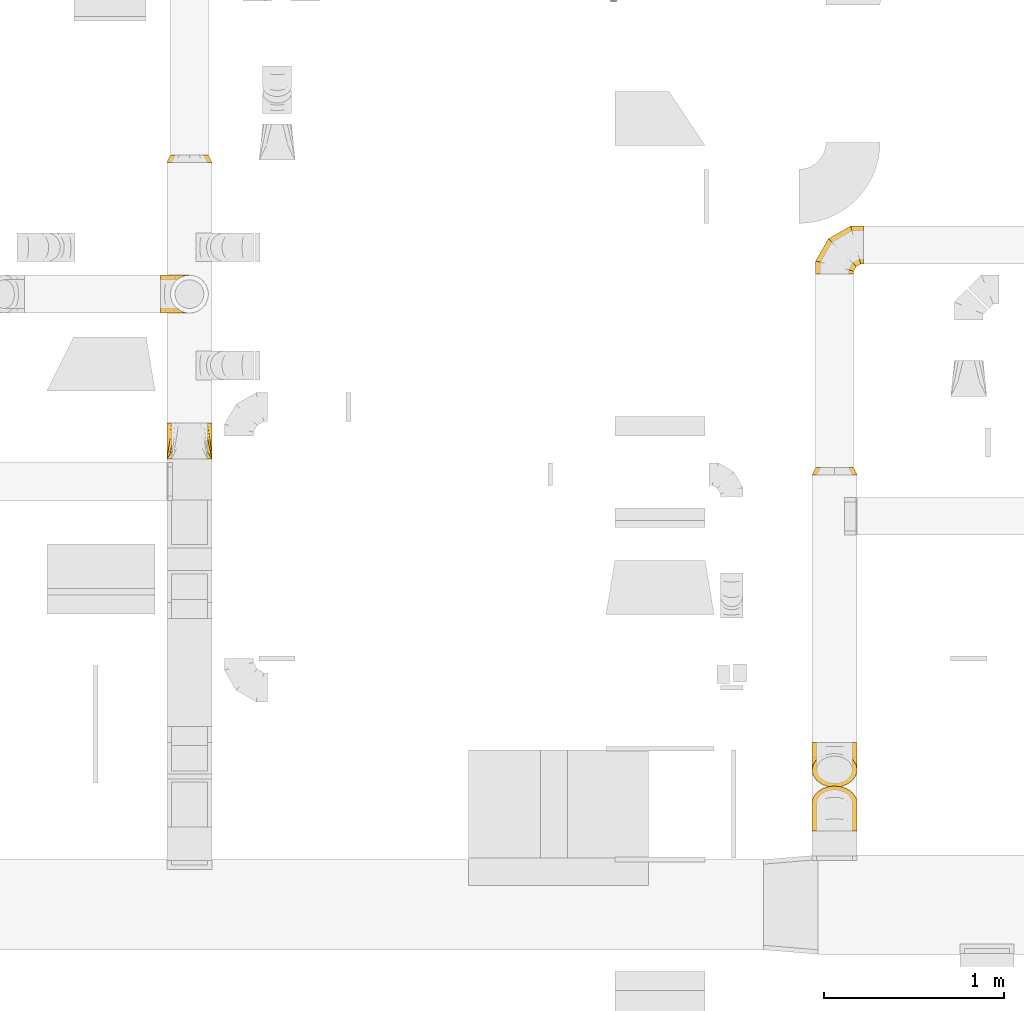
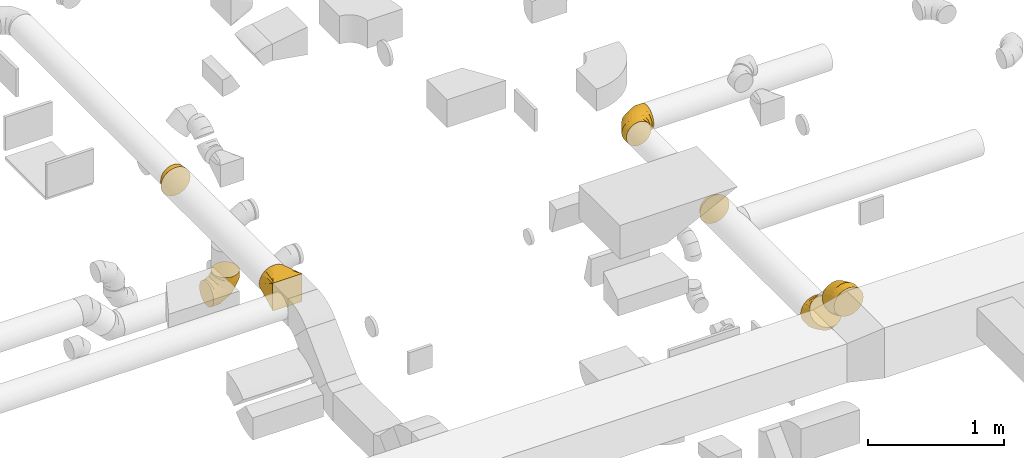
# One storey, part 9 of 62: 7 coverings.
"""IFC2X3 building model written with IfcOpenShell, lengths in millimetres."""

from ifc_helpers import new_model, entity, si_unit, converted_unit, derived_unit, direction, frame, origin, place, context, subcontext, project, spatial, faceted_brep, element, save


model = new_model("IFC2X3")

# Units and contexts
model_context = context("Model", 3, precision=0.01, world=origin(), true_north=direction((6.12303176911189e-17, 1.0)))
body_context = subcontext(model_context, "Body", "Model", "MODEL_VIEW")
ifc_project = project(units=[si_unit("LENGTHUNIT", "METRE", prefix="MILLI"), si_unit("AREAUNIT", "SQUARE_METRE"), si_unit("VOLUMEUNIT", "CUBIC_METRE"), converted_unit("PLANEANGLEUNIT", "DEGREE", entity("IfcRatioMeasure", 0.0174532925199433), si_unit("PLANEANGLEUNIT", "RADIAN"), dimensions=[0, 0, 0, 0, 0, 0, 0]), si_unit("MASSUNIT", "GRAM", prefix="KILO"), derived_unit("MASSDENSITYUNIT", [(si_unit("MASSUNIT", "GRAM", prefix="KILO"), 1), (si_unit("LENGTHUNIT", "METRE"), -3)]), derived_unit("MOMENTOFINERTIAUNIT", [(si_unit("LENGTHUNIT", "METRE"), 4)]), si_unit("TIMEUNIT", "SECOND"), si_unit("FREQUENCYUNIT", "HERTZ"), si_unit("THERMODYNAMICTEMPERATUREUNIT", "DEGREE_CELSIUS"), derived_unit("THERMALTRANSMITTANCEUNIT", [(si_unit("MASSUNIT", "GRAM", prefix="KILO"), 1), (si_unit("THERMODYNAMICTEMPERATUREUNIT", "KELVIN"), -1), (si_unit("TIMEUNIT", "SECOND"), -3)]), derived_unit("VOLUMETRICFLOWRATEUNIT", [(si_unit("LENGTHUNIT", "METRE"), 3), (si_unit("TIMEUNIT", "SECOND"), -1)]), derived_unit("MASSFLOWRATEUNIT", [(si_unit("MASSUNIT", "GRAM", prefix="KILO"), 1), (si_unit("TIMEUNIT", "SECOND"), -1)]), derived_unit("ROTATIONALFREQUENCYUNIT", [(si_unit("TIMEUNIT", "SECOND"), -1)]), si_unit("ELECTRICCURRENTUNIT", "AMPERE"), si_unit("ELECTRICVOLTAGEUNIT", "VOLT"), si_unit("POWERUNIT", "WATT"), si_unit("FORCEUNIT", "NEWTON", prefix="KILO"), si_unit("ILLUMINANCEUNIT", "LUX"), si_unit("LUMINOUSFLUXUNIT", "LUMEN"), si_unit("LUMINOUSINTENSITYUNIT", "CANDELA"), derived_unit("USERDEFINED", [(si_unit("MASSUNIT", "GRAM", prefix="KILO"), -1), (si_unit("LENGTHUNIT", "METRE"), -2), (si_unit("TIMEUNIT", "SECOND"), 3), (si_unit("LUMINOUSFLUXUNIT", "LUMEN"), 1)]), derived_unit("LINEARVELOCITYUNIT", [(si_unit("LENGTHUNIT", "METRE"), 1), (si_unit("TIMEUNIT", "SECOND"), -1)]), si_unit("PRESSUREUNIT", "PASCAL"), derived_unit("USERDEFINED", [(si_unit("LENGTHUNIT", "METRE"), -2), (si_unit("MASSUNIT", "GRAM", prefix="KILO"), 1), (si_unit("TIMEUNIT", "SECOND"), -2)]), derived_unit("LINEARFORCEUNIT", [(si_unit("MASSUNIT", "GRAM", prefix="KILO"), 1), (si_unit("LENGTHUNIT", "METRE"), 1), (si_unit("TIMEUNIT", "SECOND"), -2), (si_unit("LENGTHUNIT", "METRE"), -1)]), derived_unit("PLANARFORCEUNIT", [(si_unit("MASSUNIT", "GRAM", prefix="KILO"), 1), (si_unit("LENGTHUNIT", "METRE"), 1), (si_unit("TIMEUNIT", "SECOND"), -2), (si_unit("LENGTHUNIT", "METRE"), -2)])], contexts=[model_context])

# Site, building, storey
site_placement = place(None, origin())
site = spatial("IfcSite", under=ifc_project, at=site_placement, CompositionType="ELEMENT")
building_placement = place(site_placement, origin())
building = spatial("IfcBuilding", under=site, at=building_placement, CompositionType="ELEMENT")
storey_placement = place(building_placement, frame((0.0, 0.0, 24000.0)))
storey = spatial("IfcBuildingStorey", under=building, at=storey_placement, CompositionType="ELEMENT", Elevation=24000.0)

# Coverings
covering_1_placement = place(storey_placement, frame((50630.03, 13040.58, 3523.4)))
element("IfcCovering", 1, at=covering_1_placement, inside=storey, PredefinedType="INSULATION", context=body_context, shape_type="Brep", body=[
    faceted_brep([(159.04, 40.0, 246.46), (188.31, 40.0, 231.54), (211.54, 40.0, 208.31), (226.46, 40.0, 179.04), (231.6, 40.0, 146.6), (226.46, 40.0, 114.15), (211.54, 40.0, 84.88), (188.31, 40.0, 61.65), (159.04, 40.0, 46.73), (126.6, 40.0, 41.6), (94.15, 40.0, 46.73), (64.88, 40.0, 61.65), (41.65, 40.0, 84.88), (26.73, 40.0, 114.15), (21.6, 40.0, 146.6), (26.73, 40.0, 179.04), (41.65, 40.0, 208.31), (64.88, 40.0, 231.54), (94.15, 40.0, 246.46), (126.6, 40.0, 251.6), (126.6, 0.0, 251.6), (87.97, 0.0, 245.48), (53.12, 0.0, 227.72), (25.47, 0.0, 200.07), (7.71, 0.0, 165.22), (1.6, 0.0, 126.6), (7.71, 0.0, 87.97), (25.47, 0.0, 53.12), (53.12, 0.0, 25.47), (87.97, 0.0, 7.71), (126.6, 0.0, 1.6), (165.22, 0.0, 7.71), (200.07, 0.0, 25.47), (227.72, 0.0, 53.12), (245.48, 0.0, 87.97), (251.6, 0.0, 126.6), (245.48, 0.0, 165.22), (227.72, 0.0, 200.07), (200.07, 0.0, 227.72), (165.22, 0.0, 245.48), (237.34, 20.0, 105.59), (241.74, 19.72, 136.46), (242.49, 18.21, 135.7), (229.06, 20.0, 84.39), (207.91, 20.0, 55.28), (178.8, 20.0, 34.13), (157.6, 20.0, 25.85), (126.6, 18.21, 19.81), (95.59, 20.0, 25.85), (74.39, 20.0, 34.13), (45.28, 20.0, 55.28), (24.13, 20.0, 84.39), (15.85, 20.0, 105.59), (10.7, 18.21, 135.7), (11.46, 19.72, 136.46), (24.13, 20.0, 188.8), (45.28, 20.0, 217.91), (15.85, 20.0, 167.6), (95.59, 20.0, 247.34), (74.39, 20.0, 239.06), (126.6, 19.72, 251.6), (178.8, 20.0, 239.06), (207.91, 20.0, 217.91), (157.6, 20.0, 247.34), (237.34, 20.0, 167.6), (229.06, 20.0, 188.8)], [[[0, 1, 2, 3, 4, 5, 6, 7, 8, 9, 10, 11, 12, 13, 14, 15, 16, 17, 18, 19]], [[20, 21, 22, 23, 24, 25, 26, 27, 28, 29, 30, 31, 32, 33, 34, 35, 36, 37, 38, 39]], [[40, 4, 41, 42, 35]], [[35, 34, 40]], [[34, 33, 43]], [[40, 34, 43]], [[43, 33, 44]], [[43, 44, 6]], [[5, 43, 6]], [[43, 5, 40]], [[44, 7, 6]], [[7, 45, 8]], [[45, 32, 31]], [[45, 31, 46]], [[30, 46, 31]], [[9, 8, 46]], [[7, 44, 45]], [[4, 40, 5]], [[30, 47, 9, 46]], [[32, 44, 33]], [[44, 32, 45]], [[46, 8, 45]], [[47, 30, 48, 9]], [[30, 29, 48]], [[29, 28, 49]], [[48, 29, 49]], [[49, 28, 50]], [[49, 50, 11]], [[10, 49, 11]], [[49, 10, 48]], [[50, 12, 11]], [[12, 51, 13]], [[51, 27, 26]], [[51, 26, 52]], [[25, 52, 26]], [[14, 13, 52]], [[12, 50, 51]], [[9, 48, 10]], [[25, 53, 54, 14, 52]], [[27, 50, 28]], [[50, 27, 51]], [[52, 13, 51]], [[55, 23, 56]], [[55, 15, 57]], [[24, 23, 55]], [[57, 24, 55]], [[54, 53, 25, 57, 14]], [[55, 56, 16]], [[15, 55, 16]], [[25, 24, 57]], [[56, 17, 16]], [[58, 18, 59]], [[59, 22, 21]], [[22, 56, 23]], [[17, 59, 18]], [[19, 18, 58]], [[17, 56, 59]], [[14, 57, 15]], [[59, 21, 58]], [[20, 58, 21]], [[56, 22, 59]], [[19, 58, 20, 60]], [[61, 38, 62]], [[61, 0, 63]], [[39, 38, 61]], [[63, 39, 61]], [[60, 20, 63, 19]], [[61, 62, 1]], [[0, 61, 1]], [[20, 39, 63]], [[62, 2, 1]], [[64, 3, 65]], [[65, 37, 36]], [[37, 62, 38]], [[2, 65, 3]], [[4, 3, 64]], [[2, 62, 65]], [[19, 63, 0]], [[65, 36, 64]], [[35, 64, 36]], [[62, 37, 65]], [[4, 64, 35, 42, 41]]]),
])
covering_2_placement = place(storey_placement, frame((50630.03, 11395.58, 3523.4)))
element("IfcCovering", 2, at=covering_2_placement, inside=storey, PredefinedType="INSULATION", context=body_context, shape_type="Brep", body=[
    faceted_brep([(126.6, 200.0, 251.6), (132.56, 200.0, 250.65), (138.52, 200.0, 249.71), (150.44, 200.0, 247.82), (165.22, 200.0, 245.48), (182.65, 200.0, 236.6), (200.07, 200.0, 227.72), (213.9, 200.0, 213.9), (227.72, 200.0, 200.07), (236.6, 200.0, 182.65), (245.48, 200.0, 165.22), (247.82, 200.0, 150.44), (249.71, 200.0, 138.52), (250.65, 200.0, 132.56), (251.6, 200.0, 126.6), (250.65, 200.0, 120.63), (249.71, 200.0, 114.67), (247.82, 200.0, 102.75), (245.48, 200.0, 87.97), (236.6, 200.0, 70.55), (227.72, 200.0, 53.12), (213.9, 200.0, 39.3), (200.07, 200.0, 25.47), (182.65, 200.0, 16.59), (165.22, 200.0, 7.71), (150.44, 200.0, 5.37), (138.52, 200.0, 3.48), (132.56, 200.0, 2.54), (126.6, 200.0, 1.6), (120.63, 200.0, 2.54), (114.67, 200.0, 3.48), (102.75, 200.0, 5.37), (87.97, 200.0, 7.71), (70.55, 200.0, 16.59), (53.12, 200.0, 25.47), (39.3, 200.0, 39.3), (25.47, 200.0, 53.12), (16.59, 200.0, 70.55), (7.71, 200.0, 87.97), (5.37, 200.0, 102.75), (3.48, 200.0, 114.67), (2.54, 200.0, 120.63), (1.6, 200.0, 126.6), (2.54, 200.0, 132.56), (3.48, 200.0, 138.52), (5.37, 200.0, 150.44), (7.71, 200.0, 165.22), (16.59, 200.0, 182.65), (25.47, 200.0, 200.07), (39.3, 200.0, 213.9), (53.12, 200.0, 227.72), (70.55, 200.0, 236.6), (87.97, 200.0, 245.48), (102.75, 200.0, 247.82), (114.67, 200.0, 249.71), (120.63, 200.0, 250.65), (1.6, 0.0, 251.6), (1.6, 0.0, 1.6), (251.6, 0.0, 1.6), (251.6, 0.0, 251.6), (66.67, 104.11, 1.6), (22.66, 100.0, 17.31), (17.86, 26.03, 1.6), (50.4, 78.09, 1.6), (34.13, 52.06, 1.6), (119.1, 188.01, 1.6), (111.61, 176.03, 1.6), (96.63, 152.06, 1.6), (81.65, 128.09, 1.6), (1.6, 52.06, 34.13), (1.6, 78.09, 50.4), (1.6, 104.11, 66.67), (1.6, 128.09, 81.65), (1.6, 152.06, 96.63), (1.6, 176.03, 111.61), (1.6, 188.01, 119.1), (1.6, 26.03, 17.86), (1.6, 26.03, 235.33), (1.6, 52.06, 219.06), (1.6, 78.09, 202.79), (1.6, 104.11, 186.52), (1.6, 128.09, 171.54), (1.6, 152.06, 156.56), (1.6, 176.03, 141.58), (1.6, 188.01, 134.09), (17.31, 100.0, 230.53), (34.13, 52.06, 251.6), (50.4, 78.09, 251.6), (66.67, 104.11, 251.6), (81.65, 128.09, 251.6), (96.63, 152.06, 251.6), (111.61, 176.03, 251.6), (119.1, 188.01, 251.6), (17.86, 26.03, 251.6), (235.33, 26.03, 251.6), (219.06, 52.06, 251.6), (202.79, 78.09, 251.6), (186.52, 104.11, 251.6), (171.54, 128.09, 251.6), (156.56, 152.06, 251.6), (141.58, 176.03, 251.6), (134.09, 188.01, 251.6), (230.53, 100.0, 235.88), (251.6, 52.06, 219.06), (251.6, 78.09, 202.79), (251.6, 104.11, 186.52), (251.6, 128.09, 171.54), (251.6, 152.06, 156.56), (251.6, 176.03, 141.58), (251.6, 188.01, 134.09), (251.6, 26.03, 235.33), (251.6, 26.03, 17.86), (251.6, 52.06, 34.13), (251.6, 78.09, 50.4), (251.6, 104.11, 66.67), (251.6, 128.09, 81.65), (251.6, 152.06, 96.63), (251.6, 176.03, 111.61), (251.6, 188.01, 119.1), (235.88, 100.0, 22.66), (219.06, 52.06, 1.6), (202.79, 78.09, 1.6), (186.52, 104.11, 1.6), (171.54, 128.09, 1.6), (156.56, 152.06, 1.6), (141.58, 176.03, 1.6), (134.09, 188.01, 1.6), (235.33, 26.03, 1.6)], [[[0, 1, 2, 3, 4, 5, 6, 7, 8, 9, 10, 11, 12, 13, 14, 15, 16, 17, 18, 19, 20, 21, 22, 23, 24, 25, 26, 27, 28, 29, 30, 31, 32, 33, 34, 35, 36, 37, 38, 39, 40, 41, 42, 43, 44, 45, 46, 47, 48, 49, 50, 51, 52, 53, 54, 55]], [[56, 57, 58, 59]], [[60, 33, 32]], [[57, 61, 62]], [[33, 60, 63, 64]], [[65, 66, 67, 68, 60, 32, 31, 30, 29, 28]], [[62, 61, 34]], [[37, 69, 70, 71]], [[64, 34, 33]], [[38, 71, 72, 73, 74, 75, 42, 41, 40, 39]], [[36, 76, 69]], [[71, 38, 37]], [[61, 76, 35]], [[34, 64, 62]], [[76, 36, 35]], [[34, 61, 35]], [[61, 57, 76]], [[69, 37, 36]], [[57, 56, 77, 78, 79, 80, 81, 82, 83, 84, 42, 75, 74, 73, 72, 71, 70, 69, 76]], [[80, 47, 46]], [[56, 85, 77]], [[47, 80, 79, 78]], [[84, 83, 82, 81, 80, 46, 45, 44, 43, 42]], [[77, 85, 48]], [[51, 86, 87, 88]], [[78, 48, 47]], [[52, 88, 89, 90, 91, 92, 0, 55, 54, 53]], [[50, 93, 86]], [[88, 52, 51]], [[85, 93, 49]], [[48, 78, 77]], [[93, 50, 49]], [[48, 85, 49]], [[85, 56, 93]], [[86, 51, 50]], [[56, 59, 94, 95, 96, 97, 98, 99, 100, 101, 0, 92, 91, 90, 89, 88, 87, 86, 93]], [[97, 5, 4]], [[59, 102, 94]], [[5, 97, 96, 95]], [[101, 100, 99, 98, 97, 4, 3, 2, 1, 0]], [[94, 102, 6]], [[9, 103, 104, 105]], [[95, 6, 5]], [[10, 105, 106, 107, 108, 109, 14, 13, 12, 11]], [[8, 110, 103]], [[105, 10, 9]], [[102, 110, 7]], [[6, 95, 94]], [[110, 8, 7]], [[6, 102, 7]], [[102, 59, 110]], [[103, 9, 8]], [[59, 58, 111, 112, 113, 114, 115, 116, 117, 118, 14, 109, 108, 107, 106, 105, 104, 103, 110]], [[114, 19, 18]], [[58, 119, 111]], [[19, 114, 113, 112]], [[118, 117, 116, 115, 114, 18, 17, 16, 15, 14]], [[111, 119, 20]], [[23, 120, 121, 122]], [[112, 20, 19]], [[24, 122, 123, 124, 125, 126, 28, 27, 26, 25]], [[22, 127, 120]], [[122, 24, 23]], [[119, 127, 21]], [[20, 112, 111]], [[127, 22, 21]], [[20, 119, 21]], [[119, 58, 127]], [[120, 23, 22]], [[58, 57, 62, 64, 63, 60, 68, 67, 66, 65, 28, 126, 125, 124, 123, 122, 121, 120, 127]]]),
])
covering_3_placement = place(storey_placement, frame((50596.62, 12203.45, 3033.4)))
element("IfcCovering", 3, at=covering_3_placement, inside=storey, PredefinedType="INSULATION", context=body_context, shape_type="Brep", body=[
    faceted_brep([(160.0, 1.6, 266.6), (192.45, 6.73, 266.6), (221.72, 21.65, 266.6), (244.95, 44.88, 266.6), (259.86, 74.15, 266.6), (265.0, 106.6, 266.6), (259.86, 139.04, 266.6), (244.95, 168.31, 266.6), (221.72, 191.54, 266.6), (192.45, 206.46, 266.6), (160.0, 211.6, 266.6), (127.55, 206.46, 266.6), (98.28, 191.54, 266.6), (75.05, 168.31, 266.6), (60.14, 139.04, 266.6), (55.0, 106.6, 266.6), (60.14, 74.15, 266.6), (75.05, 44.88, 266.6), (98.28, 21.65, 266.6), (127.55, 6.73, 266.6), (0.0, 159.1, 15.66), (0.0, 133.77, 5.17), (0.0, 106.6, 1.6), (0.0, 79.42, 5.17), (0.0, 54.1, 15.66), (0.0, 32.35, 32.35), (0.0, 15.66, 54.1), (0.0, 5.17, 79.42), (0.0, 1.6, 106.6), (0.0, 5.17, 133.77), (0.0, 15.66, 159.1), (0.0, 32.35, 180.84), (0.0, 54.1, 197.53), (0.0, 79.42, 208.02), (0.0, 106.6, 211.6), (0.0, 133.77, 208.02), (0.0, 159.1, 197.53), (0.0, 180.84, 180.84), (0.0, 197.53, 159.1), (0.0, 208.02, 133.77), (0.0, 211.6, 106.6), (0.0, 208.02, 79.42), (0.0, 197.53, 54.1), (0.0, 180.84, 32.35), (71.01, 106.6, 1.6), (70.05, 79.42, 5.17), (67.24, 54.1, 15.66), (62.77, 32.35, 32.35), (56.94, 15.66, 54.1), (50.15, 5.17, 79.42), (42.87, 1.6, 106.6), (35.59, 5.17, 133.77), (28.8, 15.66, 159.1), (22.98, 32.35, 180.84), (18.51, 54.1, 197.53), (15.7, 79.42, 208.02), (14.74, 106.6, 211.6), (15.7, 133.77, 208.02), (18.51, 159.1, 197.53), (22.98, 180.84, 180.84), (35.59, 208.02, 133.77), (42.87, 211.6, 106.6), (28.8, 197.53, 159.1), (50.15, 208.02, 79.42), (56.94, 197.53, 54.1), (62.77, 180.84, 32.35), (67.24, 159.1, 15.66), (70.05, 133.77, 5.17), (193.99, 106.6, 72.6), (191.37, 79.42, 75.22), (183.7, 54.1, 82.9), (171.48, 32.35, 95.12), (155.56, 15.66, 111.03), (137.02, 5.17, 129.57), (117.13, 1.6, 149.47), (97.23, 5.17, 169.36), (78.7, 15.66, 187.9), (62.78, 32.35, 203.82), (50.56, 54.1, 216.03), (42.88, 79.42, 223.71), (40.26, 106.6, 226.33), (42.88, 133.77, 223.71), (50.56, 159.1, 216.03), (62.78, 180.84, 203.82), (97.23, 208.02, 169.36), (117.13, 211.6, 149.47), (78.7, 197.53, 187.9), (137.02, 208.02, 129.57), (155.56, 197.53, 111.03), (171.48, 180.84, 95.12), (183.7, 159.1, 82.9), (191.37, 133.77, 75.22), (265.0, 106.6, 195.59), (261.42, 79.42, 196.55), (250.93, 54.1, 199.36), (234.25, 32.35, 203.83), (212.5, 15.66, 209.66), (187.18, 5.17, 216.44), (160.0, 1.6, 223.72), (132.82, 5.17, 231.01), (107.5, 15.66, 237.79), (85.75, 32.35, 243.62), (69.07, 54.1, 248.09), (58.58, 79.42, 250.9), (55.0, 106.6, 251.86), (58.58, 133.77, 250.9), (69.07, 159.1, 248.09), (85.75, 180.84, 243.62), (132.82, 208.02, 231.01), (160.0, 211.6, 223.72), (107.5, 197.53, 237.79), (187.18, 208.02, 216.44), (212.5, 197.53, 209.66), (234.25, 180.84, 203.83), (250.93, 159.1, 199.36), (261.42, 133.77, 196.55)], [[[0, 1, 2, 3, 4, 5, 6, 7, 8, 9, 10, 11, 12, 13, 14, 15, 16, 17, 18, 19]], [[20, 21, 22, 23, 24, 25, 26, 27, 28, 29, 30, 31, 32, 33, 34, 35, 36, 37, 38, 39, 40, 41, 42, 43]], [[22, 44, 45, 23]], [[23, 45, 46, 24]], [[24, 46, 47, 25]], [[25, 47, 48, 26]], [[26, 48, 49, 27]], [[50, 28, 27, 49]], [[51, 52, 30, 29]], [[50, 51, 29, 28]], [[53, 31, 30, 52]], [[54, 55, 33, 32]], [[54, 32, 31, 53]], [[56, 34, 33, 55]], [[57, 58, 36, 35]], [[56, 57, 35, 34]], [[37, 36, 58, 59]], [[60, 61, 40, 39]], [[62, 60, 39, 38]], [[59, 62, 38, 37]], [[41, 40, 61, 63]], [[42, 41, 63, 64]], [[64, 65, 43, 42]], [[21, 20, 66, 67]], [[22, 21, 67, 44]], [[65, 66, 20, 43]], [[45, 44, 68, 69]], [[46, 45, 69, 70]], [[70, 71, 47, 46]], [[48, 47, 71, 72]], [[49, 48, 72, 73]], [[50, 49, 73, 74]], [[75, 76, 52, 51]], [[74, 75, 51, 50]], [[53, 52, 76, 77]], [[78, 79, 55, 54]], [[77, 78, 54, 53]], [[56, 55, 79, 80]], [[81, 82, 58, 57]], [[80, 81, 57, 56]], [[59, 58, 82, 83]], [[84, 85, 61, 60]], [[86, 84, 60, 62]], [[83, 86, 62, 59]], [[63, 61, 85, 87]], [[64, 63, 87, 88]], [[65, 64, 88, 89]], [[67, 66, 90, 91]], [[44, 67, 91, 68]], [[89, 90, 66, 65]], [[69, 68, 92, 93]], [[70, 69, 93, 94]], [[94, 95, 71, 70]], [[72, 71, 95, 96]], [[73, 72, 96, 97]], [[74, 73, 97, 98]], [[99, 100, 76, 75]], [[98, 99, 75, 74]], [[77, 76, 100, 101]], [[102, 103, 79, 78]], [[101, 102, 78, 77]], [[80, 79, 103, 104]], [[105, 106, 82, 81]], [[104, 105, 81, 80]], [[83, 82, 106, 107]], [[108, 109, 85, 84]], [[110, 108, 84, 86]], [[107, 110, 86, 83]], [[87, 85, 109, 111]], [[88, 87, 111, 112]], [[89, 88, 112, 113]], [[91, 90, 114, 115]], [[68, 91, 115, 92]], [[113, 114, 90, 89]], [[93, 5, 4]], [[94, 4, 3]], [[5, 93, 92]], [[93, 4, 94]], [[3, 95, 94]], [[96, 2, 1]], [[97, 1, 0]], [[95, 2, 96]], [[96, 1, 97]], [[0, 98, 97]], [[2, 95, 3]], [[99, 0, 19]], [[100, 19, 18]], [[99, 98, 0]], [[100, 99, 19]], [[18, 101, 100]], [[102, 17, 16]], [[103, 16, 15]], [[102, 101, 17]], [[104, 103, 15]], [[102, 16, 103]], [[17, 101, 18]], [[105, 15, 14]], [[106, 14, 13]], [[105, 104, 15]], [[106, 105, 14]], [[13, 107, 106]], [[110, 12, 11]], [[108, 11, 10]], [[110, 107, 12]], [[109, 108, 10]], [[110, 11, 108]], [[12, 107, 13]], [[9, 8, 112]], [[10, 9, 111]], [[10, 111, 109]], [[111, 9, 112]], [[8, 113, 112]], [[114, 7, 6]], [[115, 6, 5]], [[113, 7, 114]], [[115, 114, 6]], [[92, 115, 5]], [[7, 113, 8]]]),
])
covering_4_placement = place(storey_placement, frame((54206.92, 9574.79, 3073.4)))
element("IfcCovering", 4, at=covering_4_placement, inside=storey, PredefinedType="INSULATION", context=body_context, shape_type="Brep", body=[
    faceted_brep([(165.22, 188.42, 274.45), (126.6, 193.11, 278.39), (87.97, 188.42, 274.45), (53.12, 174.82, 263.04), (25.47, 153.63, 245.27), (7.71, 126.94, 222.87), (1.6, 97.35, 198.04), (7.71, 67.76, 173.21), (25.47, 41.07, 150.81), (53.12, 19.88, 133.03), (87.97, 6.28, 121.62), (126.6, 1.6, 117.69), (165.22, 6.28, 121.62), (200.07, 19.88, 133.03), (227.72, 41.07, 150.81), (245.48, 67.76, 173.21), (251.6, 97.35, 198.04), (245.48, 126.94, 222.87), (227.72, 153.63, 245.27), (200.07, 174.82, 263.04), (158.95, 250.56, 5.85), (126.6, 250.56, 1.6), (94.24, 250.56, 5.85), (64.1, 250.56, 18.34), (38.21, 250.56, 38.21), (18.34, 250.56, 64.1), (5.85, 250.56, 94.24), (1.6, 250.56, 126.6), (5.85, 250.56, 158.95), (18.34, 250.56, 189.1), (38.21, 250.56, 214.98), (64.1, 250.56, 234.85), (94.24, 250.56, 247.34), (126.6, 250.56, 251.6), (158.95, 250.56, 247.34), (189.1, 250.56, 234.85), (214.98, 250.56, 214.98), (234.85, 250.56, 189.1), (247.34, 250.56, 158.95), (251.6, 250.56, 126.6), (247.34, 250.56, 94.24), (234.85, 250.56, 64.1), (214.98, 250.56, 38.21), (189.1, 250.56, 18.34), (126.6, 178.51, 1.6), (94.24, 179.45, 5.85), (64.1, 182.22, 18.34), (38.21, 186.63, 38.21), (18.34, 192.36, 64.1), (5.85, 199.05, 94.24), (1.6, 206.22, 126.6), (5.85, 213.39, 158.95), (18.34, 220.08, 189.1), (38.21, 225.82, 214.98), (64.1, 230.22, 234.85), (94.24, 232.99, 247.34), (126.6, 233.93, 251.6), (158.95, 232.99, 247.34), (189.1, 230.22, 234.85), (214.98, 225.82, 214.98), (247.34, 213.39, 158.95), (251.6, 206.22, 126.6), (234.85, 220.08, 189.1), (247.34, 199.05, 94.24), (234.85, 192.36, 64.1), (214.98, 186.63, 38.21), (189.1, 182.22, 18.34), (158.95, 179.45, 5.85), (126.6, 47.91, 62.5), (94.24, 50.56, 65.96), (64.1, 58.35, 76.1), (38.21, 70.74, 92.25), (18.34, 86.88, 113.28), (5.85, 105.68, 137.78), (1.6, 125.85, 164.07), (5.85, 146.02, 190.36), (18.34, 164.82, 214.86), (38.21, 180.97, 235.9), (64.1, 193.35, 252.04), (94.24, 201.14, 262.19), (126.6, 203.79, 265.65), (158.95, 201.14, 262.19), (189.1, 193.35, 252.04), (214.98, 180.97, 235.9), (247.34, 146.02, 190.36), (251.6, 125.85, 164.07), (234.85, 164.82, 214.86), (247.34, 105.68, 137.78), (234.85, 86.88, 113.28), (214.98, 70.74, 92.25), (189.1, 58.35, 76.1), (158.95, 50.56, 65.96)], [[[0, 1, 2, 3, 4, 5, 6, 7, 8, 9, 10, 11, 12, 13, 14, 15, 16, 17, 18, 19]], [[20, 21, 22, 23, 24, 25, 26, 27, 28, 29, 30, 31, 32, 33, 34, 35, 36, 37, 38, 39, 40, 41, 42, 43]], [[21, 44, 45, 22]], [[22, 45, 46, 23]], [[47, 24, 23, 46]], [[24, 47, 48, 25]], [[25, 48, 49, 26]], [[50, 27, 26, 49]], [[51, 52, 29, 28]], [[50, 51, 28, 27]], [[53, 30, 29, 52]], [[54, 55, 32, 31]], [[54, 31, 30, 53]], [[56, 33, 32, 55]], [[57, 58, 35, 34]], [[56, 57, 34, 33]], [[36, 35, 58, 59]], [[60, 61, 39, 38]], [[62, 60, 38, 37]], [[59, 62, 37, 36]], [[40, 39, 61, 63]], [[41, 40, 63, 64]], [[42, 41, 64, 65]], [[20, 43, 66, 67]], [[21, 20, 67, 44]], [[65, 66, 43, 42]], [[45, 44, 68, 69]], [[46, 45, 69, 70]], [[70, 71, 47, 46]], [[48, 47, 71, 72]], [[49, 48, 72, 73]], [[50, 49, 73, 74]], [[75, 76, 52, 51]], [[74, 75, 51, 50]], [[53, 52, 76, 77]], [[78, 79, 55, 54]], [[77, 78, 54, 53]], [[56, 55, 79, 80]], [[81, 82, 58, 57]], [[80, 81, 57, 56]], [[59, 58, 82, 83]], [[84, 85, 61, 60]], [[86, 84, 60, 62]], [[83, 86, 62, 59]], [[63, 61, 85, 87]], [[64, 63, 87, 88]], [[65, 64, 88, 89]], [[67, 66, 90, 91]], [[44, 67, 91, 68]], [[89, 90, 66, 65]], [[69, 11, 10]], [[70, 10, 9]], [[11, 69, 68]], [[69, 10, 70]], [[9, 71, 70]], [[72, 8, 7]], [[73, 7, 6]], [[71, 8, 72]], [[72, 7, 73]], [[6, 74, 73]], [[8, 71, 9]], [[75, 6, 5]], [[76, 5, 4]], [[75, 74, 6]], [[76, 75, 5]], [[4, 77, 76]], [[78, 3, 2]], [[79, 2, 1]], [[78, 77, 3]], [[80, 79, 1]], [[78, 2, 79]], [[3, 77, 4]], [[81, 1, 0]], [[82, 0, 19]], [[81, 80, 1]], [[82, 81, 0]], [[19, 83, 82]], [[86, 18, 17]], [[84, 17, 16]], [[86, 83, 18]], [[85, 84, 16]], [[86, 17, 84]], [[18, 83, 19]], [[15, 14, 88]], [[16, 15, 87]], [[16, 87, 85]], [[87, 15, 88]], [[14, 89, 88]], [[90, 13, 12]], [[91, 12, 11]], [[89, 13, 90]], [[91, 90, 12]], [[68, 91, 11]], [[13, 89, 14]]]),
])
covering_5_placement = place(storey_placement, frame((54206.92, 9333.68, 3410.28)))
element("IfcCovering", 5, at=covering_5_placement, inside=storey, PredefinedType="INSULATION", context=body_context, shape_type="Brep", body=[
    faceted_brep([(126.6, 0.0, 28.39), (165.22, 0.0, 34.5), (200.07, 0.0, 52.26), (227.72, 0.0, 79.91), (245.48, 0.0, 114.76), (251.6, 0.0, 153.39), (245.48, 0.0, 192.01), (227.72, 0.0, 226.86), (200.07, 0.0, 254.51), (165.22, 0.0, 272.27), (126.6, 0.0, 278.39), (87.97, 0.0, 272.27), (53.12, 0.0, 254.51), (25.47, 0.0, 226.86), (7.71, 0.0, 192.01), (1.6, 0.0, 153.39), (7.71, 0.0, 114.76), (25.47, 0.0, 79.91), (53.12, 0.0, 52.26), (87.97, 0.0, 34.5), (94.24, 245.7, 159.55), (126.6, 248.96, 162.29), (158.95, 245.7, 159.55), (189.1, 236.14, 151.53), (214.98, 220.92, 138.76), (234.85, 201.09, 122.12), (247.34, 177.99, 102.74), (251.6, 153.21, 81.94), (247.34, 128.43, 61.15), (234.85, 105.33, 41.77), (214.98, 85.5, 25.13), (189.1, 70.28, 12.36), (158.95, 60.72, 4.33), (126.6, 57.45, 1.6), (94.24, 60.72, 4.33), (64.1, 70.28, 12.36), (38.21, 85.5, 25.13), (18.34, 105.33, 41.77), (5.85, 128.43, 61.15), (1.6, 153.21, 81.94), (5.85, 177.99, 102.74), (18.34, 201.09, 122.12), (38.21, 220.92, 138.76), (64.1, 236.14, 151.53), (126.6, 202.65, 217.49), (158.95, 200.0, 214.03), (189.1, 192.21, 203.88), (214.98, 179.82, 187.74), (234.85, 163.68, 166.7), (247.34, 144.88, 142.2), (251.6, 124.71, 115.91), (247.34, 104.54, 89.62), (234.85, 85.74, 65.12), (214.98, 69.59, 44.08), (189.1, 57.21, 27.94), (158.95, 49.42, 17.79), (126.6, 46.77, 14.33), (94.24, 49.42, 17.79), (64.1, 57.21, 27.94), (38.21, 69.59, 44.08), (5.85, 104.54, 89.62), (1.6, 124.71, 115.91), (18.34, 85.74, 65.12), (5.85, 144.88, 142.2), (18.34, 163.68, 166.7), (38.21, 179.82, 187.74), (64.1, 192.21, 203.88), (94.24, 200.0, 214.03), (126.6, 72.05, 278.39), (158.95, 71.11, 274.13), (189.1, 68.34, 261.64), (214.98, 63.93, 241.77), (234.85, 58.19, 215.89), (247.34, 51.51, 185.74), (251.6, 44.34, 153.39), (247.34, 37.17, 121.03), (234.85, 30.48, 90.89), (214.98, 24.74, 65.0), (189.1, 20.34, 45.13), (158.95, 17.57, 32.65), (126.6, 16.63, 28.39), (94.24, 17.57, 32.65), (64.1, 20.34, 45.13), (38.21, 24.74, 65.0), (5.85, 37.17, 121.03), (1.6, 44.34, 153.39), (18.34, 30.48, 90.89), (5.85, 51.51, 185.74), (18.34, 58.19, 215.89), (38.21, 63.93, 241.77), (64.1, 68.34, 261.64), (94.24, 71.11, 274.13)], [[[0, 1, 2, 3, 4, 5, 6, 7, 8, 9, 10, 11, 12, 13, 14, 15, 16, 17, 18, 19]], [[20, 21, 22, 23, 24, 25, 26, 27, 28, 29, 30, 31, 32, 33, 34, 35, 36, 37, 38, 39, 40, 41, 42, 43]], [[21, 44, 45, 22]], [[22, 45, 46, 23]], [[47, 24, 23, 46]], [[24, 47, 48, 25]], [[25, 48, 49, 26]], [[50, 27, 26, 49]], [[51, 52, 29, 28]], [[50, 51, 28, 27]], [[53, 30, 29, 52]], [[54, 55, 32, 31]], [[54, 31, 30, 53]], [[56, 33, 32, 55]], [[57, 58, 35, 34]], [[56, 57, 34, 33]], [[36, 35, 58, 59]], [[60, 61, 39, 38]], [[62, 60, 38, 37]], [[59, 62, 37, 36]], [[40, 39, 61, 63]], [[41, 40, 63, 64]], [[42, 41, 64, 65]], [[20, 43, 66, 67]], [[21, 20, 67, 44]], [[65, 66, 43, 42]], [[45, 44, 68, 69]], [[46, 45, 69, 70]], [[70, 71, 47, 46]], [[48, 47, 71, 72]], [[49, 48, 72, 73]], [[50, 49, 73, 74]], [[75, 76, 52, 51]], [[74, 75, 51, 50]], [[53, 52, 76, 77]], [[78, 79, 55, 54]], [[77, 78, 54, 53]], [[56, 55, 79, 80]], [[81, 82, 58, 57]], [[80, 81, 57, 56]], [[59, 58, 82, 83]], [[84, 85, 61, 60]], [[86, 84, 60, 62]], [[83, 86, 62, 59]], [[63, 61, 85, 87]], [[64, 63, 87, 88]], [[65, 64, 88, 89]], [[67, 66, 90, 91]], [[44, 67, 91, 68]], [[89, 90, 66, 65]], [[69, 10, 9]], [[70, 9, 8]], [[10, 69, 68]], [[69, 9, 70]], [[8, 71, 70]], [[72, 7, 6]], [[73, 6, 5]], [[71, 7, 72]], [[72, 6, 73]], [[5, 74, 73]], [[7, 71, 8]], [[75, 5, 4]], [[76, 4, 3]], [[75, 74, 5]], [[76, 75, 4]], [[3, 77, 76]], [[78, 2, 1]], [[79, 1, 0]], [[78, 77, 2]], [[80, 79, 0]], [[78, 1, 79]], [[2, 77, 3]], [[81, 0, 19]], [[82, 19, 18]], [[81, 80, 0]], [[82, 81, 19]], [[18, 83, 82]], [[86, 17, 16]], [[84, 16, 15]], [[86, 83, 17]], [[85, 84, 15]], [[86, 16, 84]], [[17, 83, 18]], [[14, 13, 88]], [[15, 14, 87]], [[15, 87, 85]], [[87, 14, 88]], [[13, 89, 88]], [[90, 12, 11]], [[91, 11, 10]], [[89, 12, 90]], [[91, 90, 11]], [[68, 91, 10]], [[12, 89, 13]]]),
])
covering_6_placement = place(storey_placement, frame((54226.92, 12422.77, 3093.4)))
element("IfcCovering", 6, at=covering_6_placement, inside=storey, PredefinedType="INSULATION", context=body_context, shape_type="Brep", body=[
    faceted_brep([(106.6, 0.0, 211.6), (74.15, 0.0, 206.46), (44.88, 0.0, 191.54), (21.65, 0.0, 168.31), (6.73, 0.0, 139.04), (1.6, 0.0, 106.6), (6.73, 0.0, 74.15), (21.65, 0.0, 44.88), (44.88, 0.0, 21.65), (74.15, 0.0, 6.73), (106.6, 0.0, 1.6), (139.04, 0.0, 6.73), (168.31, 0.0, 21.65), (191.54, 0.0, 44.88), (206.46, 0.0, 74.15), (211.6, 0.0, 106.6), (206.46, 0.0, 139.04), (191.54, 0.0, 168.31), (168.31, 0.0, 191.54), (139.04, 0.0, 206.46), (266.6, 250.93, 54.1), (266.6, 261.42, 79.42), (266.6, 265.0, 106.6), (266.6, 261.42, 133.77), (266.6, 250.93, 159.1), (266.6, 234.25, 180.84), (266.6, 212.5, 197.53), (266.6, 187.18, 208.02), (266.6, 160.0, 211.6), (266.6, 132.82, 208.02), (266.6, 107.5, 197.53), (266.6, 85.75, 180.84), (266.6, 69.07, 159.1), (266.6, 58.58, 133.77), (266.6, 55.0, 106.6), (266.6, 58.58, 79.42), (266.6, 69.07, 54.1), (266.6, 85.75, 32.35), (266.6, 107.5, 15.66), (266.6, 132.82, 5.17), (266.6, 160.0, 1.6), (266.6, 187.18, 5.17), (266.6, 212.5, 15.66), (266.6, 234.25, 32.35), (195.59, 265.0, 106.6), (196.55, 261.42, 133.77), (199.36, 250.93, 159.1), (203.83, 234.25, 180.84), (209.66, 212.5, 197.53), (216.44, 187.18, 208.02), (223.72, 160.0, 211.6), (231.01, 132.82, 208.02), (237.79, 107.5, 197.53), (243.62, 85.75, 180.84), (248.09, 69.07, 159.1), (250.9, 58.58, 133.77), (251.86, 55.0, 106.6), (250.9, 58.58, 79.42), (248.09, 69.07, 54.1), (243.62, 85.75, 32.35), (231.01, 132.82, 5.17), (223.72, 160.0, 1.6), (237.79, 107.5, 15.66), (216.44, 187.18, 5.17), (209.66, 212.5, 15.66), (203.83, 234.25, 32.35), (199.36, 250.93, 54.1), (196.55, 261.42, 79.42), (72.6, 193.99, 106.6), (75.22, 191.37, 133.77), (82.9, 183.7, 159.1), (95.12, 171.48, 180.84), (111.03, 155.56, 197.53), (129.57, 137.02, 208.02), (149.47, 117.13, 211.6), (169.36, 97.23, 208.02), (187.9, 78.7, 197.53), (203.82, 62.78, 180.84), (216.03, 50.56, 159.1), (223.71, 42.88, 133.77), (226.33, 40.26, 106.6), (223.71, 42.88, 79.42), (216.03, 50.56, 54.1), (203.82, 62.78, 32.35), (169.36, 97.23, 5.17), (149.47, 117.13, 1.6), (187.9, 78.7, 15.66), (129.57, 137.02, 5.17), (111.03, 155.56, 15.66), (95.12, 171.48, 32.35), (82.9, 183.7, 54.1), (75.22, 191.37, 79.42), (1.6, 71.01, 106.6), (5.17, 70.05, 133.77), (15.66, 67.24, 159.1), (32.35, 62.77, 180.84), (54.1, 56.94, 197.53), (79.42, 50.15, 208.02), (106.6, 42.87, 211.6), (133.77, 35.59, 208.02), (159.1, 28.8, 197.53), (180.84, 22.98, 180.84), (197.53, 18.51, 159.1), (208.02, 15.7, 133.77), (211.6, 14.74, 106.6), (208.02, 15.7, 79.42), (197.53, 18.51, 54.1), (180.84, 22.98, 32.35), (133.77, 35.59, 5.17), (106.6, 42.87, 1.6), (159.1, 28.8, 15.66), (79.42, 50.15, 5.17), (54.1, 56.94, 15.66), (32.35, 62.77, 32.35), (15.66, 67.24, 54.1), (5.17, 70.05, 79.42)], [[[0, 1, 2, 3, 4, 5, 6, 7, 8, 9, 10, 11, 12, 13, 14, 15, 16, 17, 18, 19]], [[20, 21, 22, 23, 24, 25, 26, 27, 28, 29, 30, 31, 32, 33, 34, 35, 36, 37, 38, 39, 40, 41, 42, 43]], [[22, 44, 45, 23]], [[23, 45, 46, 24]], [[24, 46, 47, 25]], [[25, 47, 48, 26]], [[26, 48, 49, 27]], [[50, 28, 27, 49]], [[51, 52, 30, 29]], [[50, 51, 29, 28]], [[53, 31, 30, 52]], [[54, 55, 33, 32]], [[54, 32, 31, 53]], [[56, 34, 33, 55]], [[57, 58, 36, 35]], [[56, 57, 35, 34]], [[37, 36, 58, 59]], [[60, 61, 40, 39]], [[62, 60, 39, 38]], [[59, 62, 38, 37]], [[41, 40, 61, 63]], [[42, 41, 63, 64]], [[64, 65, 43, 42]], [[21, 20, 66, 67]], [[22, 21, 67, 44]], [[65, 66, 20, 43]], [[45, 44, 68, 69]], [[46, 45, 69, 70]], [[70, 71, 47, 46]], [[48, 47, 71, 72]], [[49, 48, 72, 73]], [[50, 49, 73, 74]], [[75, 76, 52, 51]], [[74, 75, 51, 50]], [[53, 52, 76, 77]], [[78, 79, 55, 54]], [[77, 78, 54, 53]], [[56, 55, 79, 80]], [[81, 82, 58, 57]], [[80, 81, 57, 56]], [[59, 58, 82, 83]], [[84, 85, 61, 60]], [[86, 84, 60, 62]], [[83, 86, 62, 59]], [[63, 61, 85, 87]], [[64, 63, 87, 88]], [[65, 64, 88, 89]], [[67, 66, 90, 91]], [[44, 67, 91, 68]], [[89, 90, 66, 65]], [[69, 68, 92, 93]], [[70, 69, 93, 94]], [[94, 95, 71, 70]], [[72, 71, 95, 96]], [[73, 72, 96, 97]], [[74, 73, 97, 98]], [[99, 100, 76, 75]], [[98, 99, 75, 74]], [[77, 76, 100, 101]], [[102, 103, 79, 78]], [[101, 102, 78, 77]], [[80, 79, 103, 104]], [[105, 106, 82, 81]], [[104, 105, 81, 80]], [[83, 82, 106, 107]], [[108, 109, 85, 84]], [[110, 108, 84, 86]], [[107, 110, 86, 83]], [[87, 85, 109, 111]], [[88, 87, 111, 112]], [[89, 88, 112, 113]], [[91, 90, 114, 115]], [[68, 91, 115, 92]], [[113, 114, 90, 89]], [[93, 5, 4]], [[94, 4, 3]], [[5, 93, 92]], [[93, 4, 94]], [[3, 95, 94]], [[96, 2, 1]], [[97, 1, 0]], [[95, 2, 96]], [[96, 1, 97]], [[0, 98, 97]], [[2, 95, 3]], [[99, 0, 19]], [[100, 19, 18]], [[99, 98, 0]], [[100, 99, 19]], [[18, 101, 100]], [[102, 17, 16]], [[103, 16, 15]], [[102, 101, 17]], [[104, 103, 15]], [[102, 16, 103]], [[17, 101, 18]], [[105, 15, 14]], [[106, 14, 13]], [[105, 104, 15]], [[106, 105, 14]], [[13, 107, 106]], [[110, 12, 11]], [[108, 11, 10]], [[110, 107, 12]], [[109, 108, 10]], [[110, 11, 108]], [[12, 107, 13]], [[9, 8, 112]], [[10, 9, 111]], [[10, 111, 109]], [[111, 9, 112]], [[8, 113, 112]], [[114, 7, 6]], [[115, 6, 5]], [[113, 7, 114]], [[115, 114, 6]], [[92, 115, 5]], [[7, 113, 8]]]),
])
covering_7_placement = place(storey_placement, frame((54206.92, 11307.77, 3073.4)))
element("IfcCovering", 7, at=covering_7_placement, inside=storey, PredefinedType="INSULATION", context=body_context, shape_type="Brep", body=[
    faceted_brep([(87.97, 0.0, 245.48), (53.12, 0.0, 227.72), (25.47, 0.0, 200.07), (7.71, 0.0, 165.22), (1.6, 0.0, 126.6), (7.71, 0.0, 87.97), (25.47, 0.0, 53.12), (53.12, 0.0, 25.47), (87.97, 0.0, 7.71), (126.6, 0.0, 1.6), (165.22, 0.0, 7.71), (200.07, 0.0, 25.47), (227.72, 0.0, 53.12), (245.48, 0.0, 87.97), (251.6, 0.0, 126.6), (245.48, 0.0, 165.22), (227.72, 0.0, 200.07), (200.07, 0.0, 227.72), (165.22, 0.0, 245.48), (126.6, 0.0, 251.6), (94.15, 40.0, 226.46), (126.6, 40.0, 231.6), (159.04, 40.0, 226.46), (188.31, 40.0, 211.54), (211.54, 40.0, 188.31), (226.46, 40.0, 159.04), (231.6, 40.0, 126.6), (226.46, 40.0, 94.15), (211.54, 40.0, 64.88), (188.31, 40.0, 41.65), (159.04, 40.0, 26.73), (126.6, 40.0, 21.6), (94.15, 40.0, 26.73), (64.88, 40.0, 41.65), (41.65, 40.0, 64.88), (26.73, 40.0, 94.15), (21.6, 40.0, 126.6), (26.73, 40.0, 159.04), (41.65, 40.0, 188.31), (64.88, 40.0, 211.54)], [[[0, 1, 2, 3, 4, 5, 6, 7, 8, 9, 10, 11, 12, 13, 14, 15, 16, 17, 18, 19]], [[20, 21, 22, 23, 24, 25, 26, 27, 28, 29, 30, 31, 32, 33, 34, 35, 36, 37, 38, 39]], [[35, 34, 6, 5]], [[36, 35, 5, 4]], [[34, 33, 7, 6]], [[8, 7, 33, 32]], [[8, 32, 31, 9]], [[30, 29, 11, 10]], [[31, 30, 10, 9]], [[29, 28, 12, 11]], [[13, 12, 28, 27]], [[13, 27, 26, 14]], [[25, 24, 16, 15]], [[26, 25, 15, 14]], [[24, 23, 17, 16]], [[18, 17, 23, 22]], [[18, 22, 21, 19]], [[20, 39, 1, 0]], [[21, 20, 0, 19]], [[39, 38, 2, 1]], [[3, 2, 38, 37]], [[3, 37, 36, 4]]]),
])

save(model, "model.ifc")
